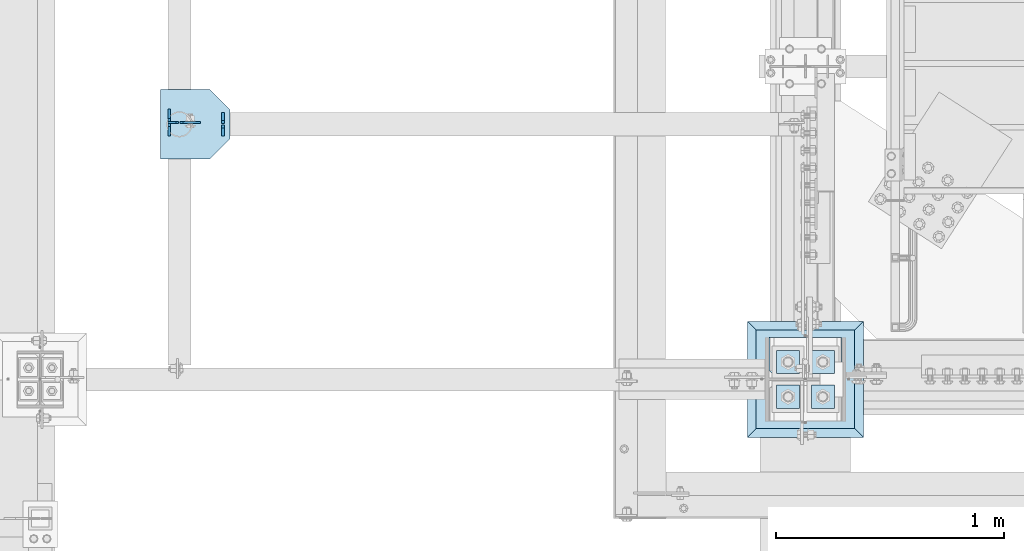
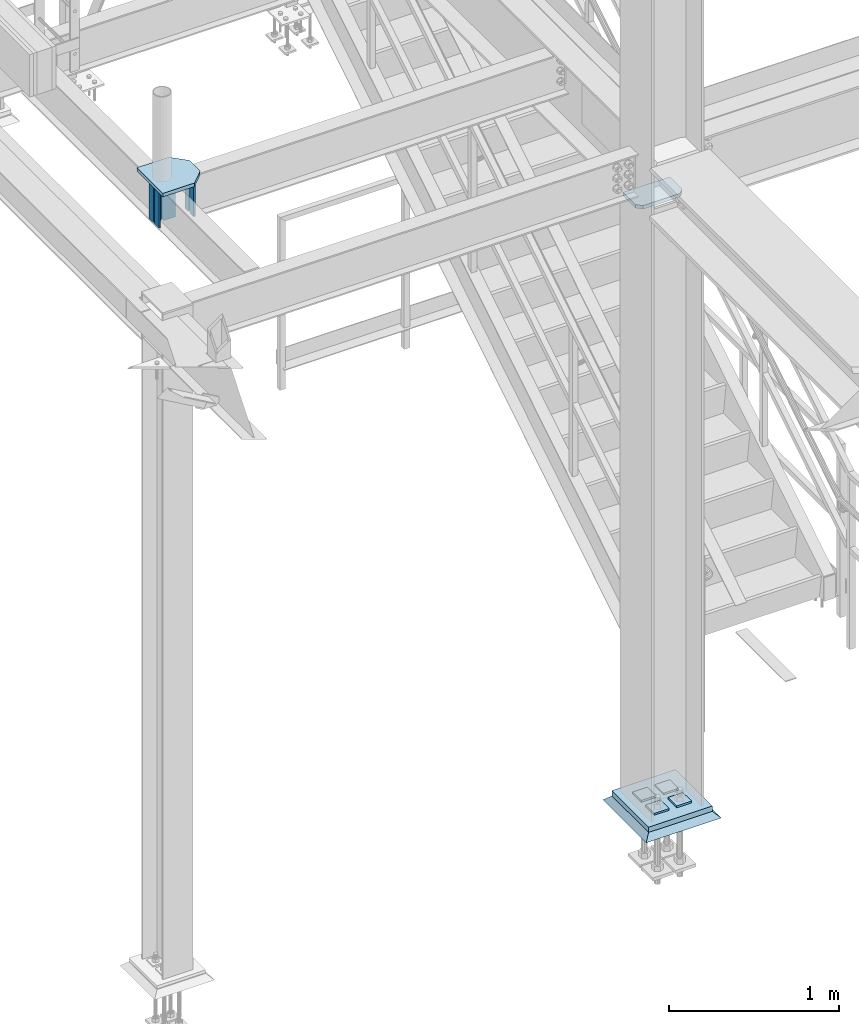
# One storey, part 3019 of 3843: 14 plates, 5 elements without a shape of their own.
"""IFC2X3 building model written with IfcOpenShell, lengths in millimetres."""

from ifc_helpers import new_model, si_unit, frame, origin_with_axes, place, context, subcontext, project, spatial, faceted_brep, material, type_object, element, aggregate, save


model = new_model("IFC2X3")

# Units and contexts
model_context = context("Model", 3, precision=1e-05, world=origin_with_axes())
body_context = subcontext(model_context, "Body", "Model", "MODEL_VIEW")
ifc_project = project(units=[si_unit("LENGTHUNIT", "METRE", prefix="MILLI"), si_unit("AREAUNIT", "SQUARE_METRE"), si_unit("VOLUMEUNIT", "CUBIC_METRE"), si_unit("MASSUNIT", "GRAM", prefix="KILO"), si_unit("TIMEUNIT", "SECOND"), si_unit("PLANEANGLEUNIT", "RADIAN"), si_unit("SOLIDANGLEUNIT", "STERADIAN"), si_unit("THERMODYNAMICTEMPERATUREUNIT", "DEGREE_CELSIUS"), si_unit("LUMINOUSINTENSITYUNIT", "LUMEN")], contexts=[model_context])

# Site, building, storey
site_placement = place(None, origin_with_axes())
site = spatial("IfcSite", under=ifc_project, at=site_placement, CompositionType="ELEMENT")
building_placement = place(site_placement, origin_with_axes())
building = spatial("IfcBuilding", under=site, at=building_placement, Name="Undefined", CompositionType="ELEMENT")
storey_placement = place(building_placement, origin_with_axes())
storey = spatial("IfcBuildingStorey", under=building, at=storey_placement, Name="Undefined", CompositionType="ELEMENT", Elevation=0.0)

# Assembly, plate
assembly_1_placement = place(storey_placement, origin_with_axes())
assembly_1 = element("IfcElementAssembly", 1, at=assembly_1_placement, inside=storey, Name="COLUMN", AssemblyPlace="NOTDEFINED", PredefinedType="RIGID_FRAME")
ifc_material_1 = material(Name="STEEL/A572-50")
plate_type_1 = type_object("IfcPlateType", PredefinedType="NOTDEFINED")
plate_1_placement = place(assembly_1_placement, frame((36734.75, 25799.25625, 34372.55), z_axis=(-1.0, 0.0, 0.0), x_axis=(0.0, -1.0, 0.0)))
plate_1 = element("IfcPlate", 2, at=plate_1_placement, type_object=plate_type_1, material=ifc_material_1, Name="PLATE", context=body_context, shape_type="Brep", body=[
    faceted_brep([(0.0, -12.6999999999971, 0.0), (0.0, -12.7000000020344, 317.500000001608), (0.0, 12.6999999977998, 317.500000001586), (0.0, 12.6999999999971, 0.0), (144.462501525879, -12.6999999999971, 317.5), (144.462501525879, 12.6999999999971, 317.5), (177.800003051758, -12.6999999999971, 284.162498474121), (177.800003051758, 12.6999999999971, 284.162498474121), (177.800003051758, -12.6999999999971, 33.3375015258789), (177.800003051758, 12.6999999999971, 33.3375015258789), (144.462501525879, -12.6999999999971, 0.0), (144.462501525879, 12.6999999999971, 0.0)], [[[0, 1, 2, 3]], [[1, 4, 5, 2]], [[4, 6, 7, 5]], [[6, 8, 9, 7]], [[8, 10, 11, 9]], [[10, 0, 3, 11]], [[5, 7, 9, 11, 3, 2]], [[10, 8, 6, 4, 1, 0]]]),
])

# Assembly, plates
assembly_2_placement = place(storey_placement, origin_with_axes())
assembly_2 = element("IfcElementAssembly", 3, at=assembly_2_placement, inside=storey, Name="BEAM", AssemblyPlace="NOTDEFINED", PredefinedType="RIGID_FRAME")
plate_type_2 = type_object("IfcPlateType", PredefinedType="NOTDEFINED")
plate_2_placement = place(assembly_2_placement, frame((33835.975, 26741.4379999161, 34513.8375), z_axis=(0.0, 0.0, 1.0), x_axis=(1.0, 0.0, 0.0)))
plate_2 = element("IfcPlate", 4, at=plate_2_placement, type_object=plate_type_2, material=ifc_material_1, Name="PLATE", context=body_context, shape_type="Brep", body=[
    faceted_brep([(0.0, -4.76250000000073, 12.6999998092651), (0.0, -4.76250000000073, 273.050000188858), (0.0, 4.76250000000073, 273.050000188858), (0.0, 4.76250000000073, 12.6999998092651), (12.6999998092651, -4.76250000000073, 285.749999998123), (12.6999998092651, 4.76250000000073, 285.749999998123), (88.8999999999942, -4.76250000000073, 285.75), (88.8999999999942, 4.76250000000073, 285.75), (88.8999999999942, -4.76250000000073, 0.0), (88.8999999999942, 4.76250000000073, 0.0), (12.6999998092651, -4.76250000000073, 0.0), (12.6999998092651, 4.76250000000073, 0.0)], [[[0, 1, 2, 3]], [[1, 4, 5, 2]], [[4, 6, 7, 5]], [[6, 8, 9, 7]], [[8, 10, 11, 9]], [[10, 0, 3, 11]], [[5, 7, 9, 11, 3, 2]], [[10, 8, 6, 4, 1, 0]]]),
])
plate_type_3 = type_object("IfcPlateType", PredefinedType="NOTDEFINED")
plate_3_placement = place(assembly_2_placement, frame((33788.35, 26682.7, 34513.8375), z_axis=(0.0, 0.0, 1.0), x_axis=(0.0, 1.0, 0.0)))
plate_3 = element("IfcPlate", 5, at=plate_3_placement, type_object=plate_type_3, material=ifc_material_1, Name="STIFFENER", context=body_context, shape_type="Brep", body=[
    faceted_brep([(0.0, -6.3499999046162, 0.0), (0.0, -6.34999999999854, 285.75), (0.0, 6.34999999999854, 285.75), (7.27595761418343e-12, 6.3499999046162, 0.0), (41.2755001068144, -6.34999999999854, 285.75), (41.2755001068144, 6.34999999999854, 285.75), (53.9754999160796, -6.34999999999854, 273.050000190735), (53.9754999160796, 6.34999999999854, 273.050000190735), (53.9754999160796, -6.34999999999854, 12.6999998092651), (53.9754999160796, 6.34999999999854, 12.6999998092651), (41.2755001068144, -6.34999999999854, 0.0), (41.2755001068144, 6.34999999999854, 0.0)], [[[0, 1, 2, 3]], [[1, 4, 5, 2]], [[4, 6, 7, 5]], [[6, 8, 9, 7]], [[8, 10, 11, 9]], [[10, 0, 3, 11]], [[5, 7, 9, 11, 3, 2]], [[10, 8, 6, 4, 1, 0]]]),
])
plate_4_placement = place(assembly_2_placement, frame((33788.35, 26746.2004999161, 34513.8375), z_axis=(0.0, 0.0, 1.0), x_axis=(0.0, 1.0, 0.0)))
plate_4 = element("IfcPlate", 6, at=plate_4_placement, type_object=plate_type_3, material=ifc_material_1, Name="STIFFENER", context=body_context, shape_type="Brep", body=[
    faceted_brep([(0.0, -6.34999999999854, 12.6999998092651), (0.0, -6.34999999999854, 273.050000190735), (0.0, 6.34999999999854, 273.050000190735), (0.0, 6.34999999999854, 12.6999998092651), (12.6999998092651, -6.34999999999854, 285.75), (12.6999998092651, 6.34999999999854, 285.75), (53.9749999999985, -6.34999999999854, 285.75), (53.9749999999985, 6.34999999999854, 285.75), (53.9749999999985, -6.34999999999854, 0.0), (53.9749999999985, 6.34999999999854, 0.0), (12.6999998092651, -6.34999999999854, 0.0), (12.6999998092651, 6.34999999999854, 0.0)], [[[0, 1, 2, 3]], [[1, 4, 5, 2]], [[4, 6, 7, 5]], [[6, 8, 9, 7]], [[8, 10, 11, 9]], [[10, 0, 3, 11]], [[5, 7, 9, 11, 3, 2]], [[10, 8, 6, 4, 1, 0]]]),
])

assembly_3_placement = place(storey_placement, origin_with_axes())
assembly_3 = element("IfcElementAssembly", 7, at=assembly_3_placement, inside=storey, Name="BEAM", AssemblyPlace="NOTDEFINED", PredefinedType="RIGID_FRAME")
plate_type_4 = type_object("IfcPlateType", PredefinedType="NOTDEFINED")
plate_5_placement = place(assembly_3_placement, frame((34023.3, 26682.7, 34513.8375), z_axis=(0.0, 0.0, 1.0), x_axis=(0.0, 1.0, 0.0)))
plate_5 = element("IfcPlate", 8, at=plate_5_placement, type_object=plate_type_4, material=ifc_material_1, Name="STIFFENER", context=body_context, shape_type="Brep", body=[
    faceted_brep([(0.0, -6.3499999046162, 0.0), (0.0, -6.34999999999854, 285.75), (0.0, 6.34999999999854, 285.75), (7.27595761418343e-12, 6.3499999046162, 0.0), (34.9250001907349, -6.34999999999854, 285.75), (34.9250001907349, 6.34999999999854, 285.75), (47.625, -6.34999999999854, 273.050000190735), (47.625, 6.34999999999854, 273.050000190735), (47.625, -6.34999999999854, 12.6999998092651), (47.625, 6.34999999999854, 12.6999998092651), (34.9250001907349, -6.34999999999854, 0.0), (34.9250001907349, 6.34999999999854, 0.0)], [[[0, 1, 2, 3]], [[1, 4, 5, 2]], [[4, 6, 7, 5]], [[6, 8, 9, 7]], [[8, 10, 11, 9]], [[10, 0, 3, 11]], [[5, 7, 9, 11, 3, 2]], [[10, 8, 6, 4, 1, 0]]]),
])
plate_6_placement = place(assembly_3_placement, frame((34023.3, 26736.675, 34513.8375), z_axis=(0.0, 0.0, 1.0), x_axis=(0.0, 1.0, 0.0)))
plate_6 = element("IfcPlate", 9, at=plate_6_placement, type_object=plate_type_4, material=ifc_material_1, Name="STIFFENER", context=body_context, shape_type="Brep", body=[
    faceted_brep([(0.0, -6.34999999999854, 12.6999998092651), (0.0, -6.34999999999854, 273.050000190735), (0.0, 6.34999999999854, 273.050000190735), (0.0, 6.34999999999854, 12.6999998092651), (12.6999998092651, -6.34999999999854, 285.75), (12.6999998092651, 6.34999999999854, 285.75), (47.625, -6.34999999999854, 285.75), (47.625, 6.34999999999854, 285.75), (47.625, -6.34999999999854, 0.0), (47.625, 6.34999999999854, 0.0), (12.6999998092651, -6.34999999999854, 0.0), (12.6999998092651, 6.34999999999854, 0.0)], [[[0, 1, 2, 3]], [[1, 4, 5, 2]], [[4, 6, 7, 5]], [[6, 8, 9, 7]], [[8, 10, 11, 9]], [[10, 0, 3, 11]], [[5, 7, 9, 11, 3, 2]], [[10, 8, 6, 4, 1, 0]]]),
])
aggregate(assembly_3, [plate_5, plate_6])

# Plate
plate_type_5 = type_object("IfcPlateType", PredefinedType="NOTDEFINED")
plate_7_placement = place(assembly_2_placement, frame((34055.05, 26581.1, 34823.4), z_axis=(-1.0, 0.0, 0.0), x_axis=(0.0, 1.0, 0.0)))
plate_7 = element("IfcPlate", 10, at=plate_7_placement, type_object=plate_type_5, material=ifc_material_1, Name="PLATE", context=body_context, shape_type="Brep", body=[
    faceted_brep([(0.0, -12.7000000000007, 88.9000015258789), (7.27595761418343e-12, -12.6999999999971, 304.800000000003), (7.27595761418343e-12, 12.6999999999971, 304.800000000003), (0.0, 12.7000000000007, 88.9000015258789), (304.800000000007, -12.6999999999971, 304.799999999996), (304.800000000007, 12.6999999999971, 304.799999999996), (304.800000000003, -12.6999999999971, 88.9000015258789), (304.800000000003, 12.6999999999971, 88.9000015258789), (215.89999847412, -12.6999999999971, 0.0), (215.89999847412, 12.6999999999971, 0.0), (88.9000015258789, -12.7000000000007, 0.0), (88.9000015258789, 12.7000000000007, 0.0)], [[[0, 1, 2, 3]], [[1, 4, 5, 2]], [[4, 6, 7, 5]], [[6, 8, 9, 7]], [[8, 10, 11, 9]], [[10, 0, 3, 11]], [[5, 7, 9, 11, 3, 2]], [[10, 8, 6, 4, 1, 0]]]),
])

plate_type_6 = type_object("IfcPlateType", PredefinedType="NOTDEFINED")
plate_8_placement = place(assembly_2_placement, frame((33829.625, 26741.4379999161, 34513.8375), z_axis=(0.0, 0.0, 1.0), x_axis=(-1.0, 0.0, 0.0)))
plate_8 = element("IfcPlate", 11, at=plate_8_placement, type_object=plate_type_6, material=ifc_material_1, Name="PLATE", context=body_context, shape_type="Brep", body=[
    faceted_brep([(0.0, -4.76250000000073, 12.6999998092651), (0.0, -4.76250000000073, 273.050000188858), (0.0, 4.76250000000073, 273.050000188858), (0.0, 4.76250000000073, 12.6999998092651), (12.6999998092651, -4.76250000000073, 285.749999998123), (12.6999998092651, 4.76250000000073, 285.749999998123), (47.625, -4.76250000000073, 285.749999998123), (47.625, 4.76250000000073, 285.749999998123), (47.625, -4.76250000000073, 0.0), (47.625, 4.76250000000073, 0.0), (12.6999998092651, -4.76250000000073, 0.0), (12.6999998092651, 4.76250000000073, 0.0)], [[[0, 1, 2, 3]], [[1, 4, 5, 2]], [[4, 6, 7, 5]], [[6, 8, 9, 7]], [[8, 10, 11, 9]], [[10, 0, 3, 11]], [[5, 7, 9, 11, 3, 2]], [[10, 8, 6, 4, 1, 0]]]),
])

aggregate(assembly_2, [plate_3, plate_4, plate_7, plate_8, plate_2])

# Assembly, plates
assembly_4_placement = place(storey_placement, origin_with_axes())
assembly_4 = element("IfcElementAssembly", 12, at=assembly_4_placement, inside=storey, Name="TEMPLATE", AssemblyPlace="NOTDEFINED", PredefinedType="RIGID_FRAME")
plate_type_7 = type_object("IfcPlateType", PredefinedType="NOTDEFINED")
plate_9_placement = place(assembly_4_placement, frame((36601.4, 25590.5, 30105.35), z_axis=(0.0, -1.0, 0.0), x_axis=(1.0, 0.0, 0.0)))
plate_9 = element("IfcPlate", 13, at=plate_9_placement, type_object=plate_type_7, material=ifc_material_1, Name="Washer Plate", context=body_context, shape_type="Brep", body=[
    faceted_brep([(0.0, -6.3499999046162, 0.0), (-1.67347025126219e-10, -6.35000000000582, 101.600000000151), (-1.67347025126219e-10, 6.35000000000582, 101.600000000151), (7.27595761418343e-12, 6.3499999046162, 0.0), (101.599998474121, -6.34999999999854, 101.599998474121), (101.599998474121, 6.34999999999854, 101.599998474121), (101.6, -6.34999999999854, 0.0), (101.6, 6.34999999999854, 0.0)], [[[0, 1, 2, 3]], [[1, 4, 5, 2]], [[4, 6, 7, 5]], [[6, 0, 3, 7]], [[5, 7, 3, 2]], [[6, 4, 1, 0]]]),
])
plate_10_placement = place(assembly_4_placement, frame((36601.4, 25742.9, 30105.35), z_axis=(0.0, -1.0, 0.0), x_axis=(1.0, 0.0, 0.0)))
plate_10 = element("IfcPlate", 14, at=plate_10_placement, type_object=plate_type_7, material=ifc_material_1, Name="Washer Plate", context=body_context, shape_type="Brep", body=[
    faceted_brep([(0.0, -6.3499999046162, 0.0), (-1.67347025126219e-10, -6.35000000000582, 101.600000000151), (-1.67347025126219e-10, 6.35000000000582, 101.600000000151), (7.27595761418343e-12, 6.3499999046162, 0.0), (101.599998474121, -6.34999999999854, 101.599998474121), (101.599998474121, 6.34999999999854, 101.599998474121), (101.6, -6.34999999999854, 0.0), (101.6, 6.34999999999854, 0.0)], [[[0, 1, 2, 3]], [[1, 4, 5, 2]], [[4, 6, 7, 5]], [[6, 0, 3, 7]], [[5, 7, 3, 2]], [[6, 4, 1, 0]]]),
])
plate_11_placement = place(assembly_4_placement, frame((36449.0, 25590.5, 30105.35), z_axis=(0.0, -1.0, 0.0), x_axis=(1.0, 0.0, 0.0)))
plate_11 = element("IfcPlate", 15, at=plate_11_placement, type_object=plate_type_7, material=ifc_material_1, Name="Washer Plate", context=body_context, shape_type="Brep", body=[
    faceted_brep([(0.0, -6.3499999046162, 0.0), (-1.67347025126219e-10, -6.35000000000582, 101.600000000151), (-1.67347025126219e-10, 6.35000000000582, 101.600000000151), (7.27595761418343e-12, 6.3499999046162, 0.0), (101.599998474121, -6.34999999999854, 101.599998474121), (101.599998474121, 6.34999999999854, 101.599998474121), (101.6, -6.34999999999854, 0.0), (101.6, 6.34999999999854, 0.0)], [[[0, 1, 2, 3]], [[1, 4, 5, 2]], [[4, 6, 7, 5]], [[6, 0, 3, 7]], [[5, 7, 3, 2]], [[6, 4, 1, 0]]]),
])
plate_12_placement = place(assembly_4_placement, frame((36449.0, 25742.9, 30105.35), z_axis=(0.0, -1.0, 0.0), x_axis=(1.0, 0.0, 0.0)))
plate_12 = element("IfcPlate", 16, at=plate_12_placement, type_object=plate_type_7, material=ifc_material_1, Name="Washer Plate", context=body_context, shape_type="Brep", body=[
    faceted_brep([(0.0, -6.3499999046162, 0.0), (-1.67347025126219e-10, -6.35000000000582, 101.600000000151), (-1.67347025126219e-10, 6.35000000000582, 101.600000000151), (7.27595761418343e-12, 6.3499999046162, 0.0), (101.599998474121, -6.34999999999854, 101.599998474121), (101.599998474121, 6.34999999999854, 101.599998474121), (101.6, -6.34999999999854, 0.0), (101.6, 6.34999999999854, 0.0)], [[[0, 1, 2, 3]], [[1, 4, 5, 2]], [[4, 6, 7, 5]], [[6, 0, 3, 7]], [[5, 7, 3, 2]], [[6, 4, 1, 0]]]),
])
aggregate(assembly_4, [plate_9, plate_10, plate_11, plate_12])

# Plate
plate_type_8 = type_object("IfcPlateType", PredefinedType="NOTDEFINED")
plate_13_placement = place(assembly_1_placement, frame((36360.1, 25400.0, 30079.95), z_axis=(0.0, 1.0, 0.0), x_axis=(1.0, 0.0, 0.0)))
plate_13 = element("IfcPlate", 17, at=plate_13_placement, type_object=plate_type_8, material=ifc_material_1, Name="PLATE", context=body_context, shape_type="Brep", body=[
    faceted_brep([(0.0, -19.0500000000029, 0.0), (0.0, -19.0499999999993, 431.799987792969), (0.0, 19.0499999999993, 431.799987792969), (0.0, 19.0500000000029, 0.0), (431.799987792969, -19.0499999999993, 431.799987792969), (431.799987792969, 19.0499999999993, 431.799987792969), (431.799957275391, -19.0499999999993, 0.0), (431.799957275391, 19.0499999999993, 0.0)], [[[0, 1, 2, 3]], [[1, 4, 5, 2]], [[4, 6, 7, 5]], [[6, 0, 3, 7]], [[5, 7, 3, 2]], [[6, 4, 1, 0]]]),
])

aggregate(assembly_1, [plate_1, plate_13])

# Assembly, plate
assembly_5_placement = place(storey_placement, origin_with_axes())
assembly_5 = element("IfcElementAssembly", 18, at=assembly_5_placement, inside=storey, Name="GROUT", AssemblyPlace="NOTDEFINED", PredefinedType="REINFORCEMENT_UNIT")
ifc_material_2 = material(Name="CONCRETE/Concrete_Undefined")
plate_type_9 = type_object("IfcPlateType", PredefinedType="NOTDEFINED")
plate_14_placement = place(assembly_5_placement, frame((36322.0, 25361.9, 30041.85), z_axis=(0.0, 1.0, 0.0), x_axis=(1.0, 0.0, 0.0)))
plate_14 = element("IfcPlate", 19, at=plate_14_placement, type_object=plate_type_9, material=ifc_material_2, Name="GROUT", context=body_context, shape_type="Brep", body=[
    faceted_brep([(38.1000000007043, -19.0499999997883, 469.899999999314), (0.0, 19.0499999999993, 508.0), (0.0, 19.0500000000029, 0.0), (38.1000000006916, -19.0499999999811, 38.1000000006607), (469.899999999325, -19.0499999998174, 38.1000000006607), (508.0, 19.0499999999993, 0.0), (508.0, 19.0499999999993, 508.0), (469.899999999325, -19.0499999999847, 469.899999999314)], [[[0, 1, 2, 3]], [[4, 5, 6, 7]], [[4, 7, 0, 3]], [[5, 4, 3, 2]], [[6, 5, 2, 1]], [[7, 6, 1, 0]]]),
])
aggregate(assembly_5, [plate_14])

save(model, "model.ifc")
